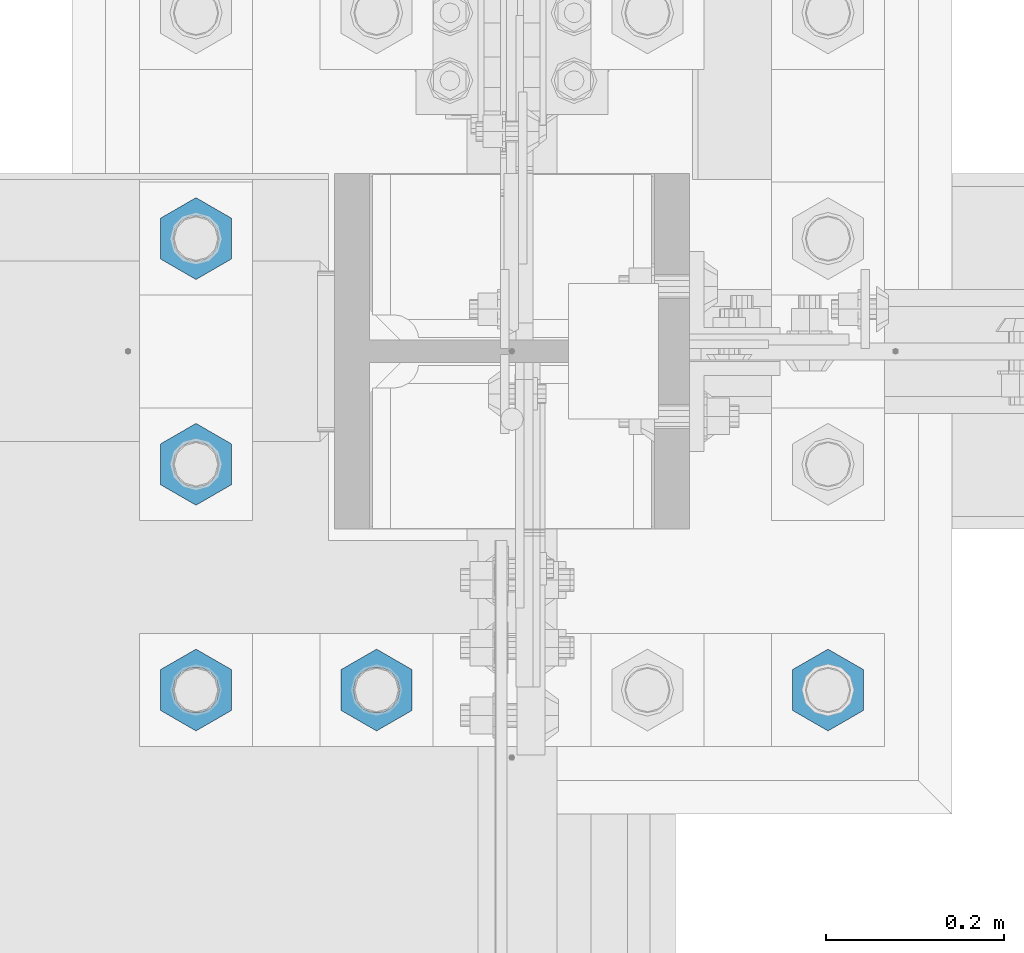
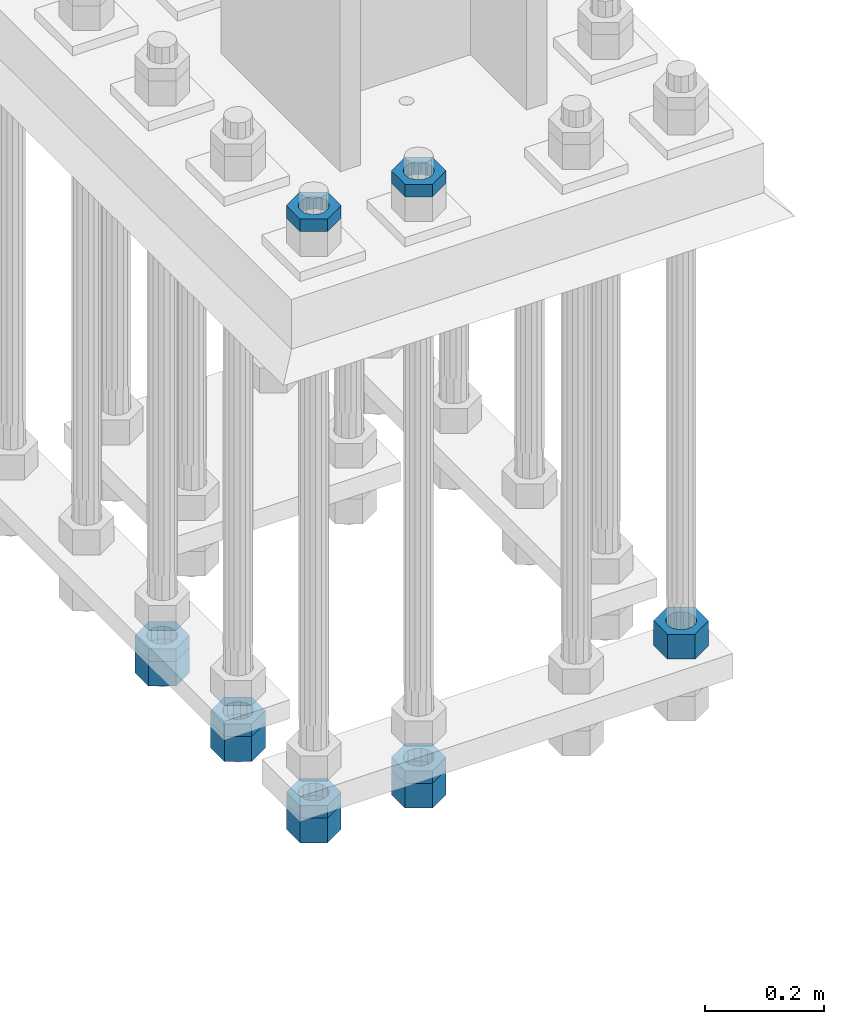
# One storey, part 2194 of 3843: 11 beams, 1 element without a shape of its own.
"""IFC2X3 building model written with IfcOpenShell, lengths in millimetres."""

from ifc_helpers import new_model, si_unit, frame, origin_with_axes, place, context, subcontext, project, spatial, faceted_brep, material, type_object, element, aggregate, save


model = new_model("IFC2X3")

# Units and contexts
model_context = context("Model", 3, precision=1e-05, world=origin_with_axes())
body_context = subcontext(model_context, "Body", "Model", "MODEL_VIEW")
ifc_project = project(units=[si_unit("LENGTHUNIT", "METRE", prefix="MILLI"), si_unit("AREAUNIT", "SQUARE_METRE"), si_unit("VOLUMEUNIT", "CUBIC_METRE"), si_unit("MASSUNIT", "GRAM", prefix="KILO"), si_unit("TIMEUNIT", "SECOND"), si_unit("PLANEANGLEUNIT", "RADIAN"), si_unit("SOLIDANGLEUNIT", "STERADIAN"), si_unit("THERMODYNAMICTEMPERATUREUNIT", "DEGREE_CELSIUS"), si_unit("LUMINOUSINTENSITYUNIT", "LUMEN")], contexts=[model_context])

# Site, building, storey
site_placement = place(None, origin_with_axes())
site = spatial("IfcSite", under=ifc_project, at=site_placement, CompositionType="ELEMENT")
building_placement = place(site_placement, origin_with_axes())
building = spatial("IfcBuilding", under=site, at=building_placement, Name="Undefined", CompositionType="ELEMENT")
storey_placement = place(building_placement, origin_with_axes())
storey = spatial("IfcBuildingStorey", under=building, at=storey_placement, Name="Undefined", CompositionType="ELEMENT", Elevation=0.0)

# Assembly, beams
assembly_placement = place(storey_placement, origin_with_axes())
assembly = element("IfcElementAssembly", 1, at=assembly_placement, inside=storey, Name="TEMPLATE", AssemblyPlace="NOTDEFINED", PredefinedType="RIGID_FRAME")
ifc_material = material(Name="STEEL/A572-50")
beam_type_1 = type_object("IfcBeamType", Name="2_HALF_NUT", PredefinedType="NOTDEFINED")
beam_1_placement = place(assembly_placement, frame((36220.4, 50177.7, 30257.75), z_axis=(1.0, 0.0, 0.0), x_axis=(0.0, 0.0, -1.0)))
beam_1 = element("IfcBeam", 2, at=beam_1_placement, type_object=beam_type_1, material=ifc_material, Name="NUT", ObjectType="2_HALF_NUT", context=body_context, shape_type="Brep", body=[
    faceted_brep([(0.0, -46.0369987487793, 0.0), (0.0, -23.0184993743896, -39.869213104248), (25.4000000000015, -23.0184993743896, -39.869213104248), (25.4000000000015, -46.0369987487793, 0.0), (0.0, 23.0184993743896, -39.869213104248), (25.4000000000015, 23.0184993743896, -39.869213104248), (0.0, 46.0369987487793, 0.0), (25.4000000000015, 46.0369987487793, 0.0), (0.0, 23.0184993743896, 39.869213104248), (25.4000000000015, 23.0184993743896, 39.869213104248), (0.0, -23.0184993743896, 39.869213104248), (25.4000000000015, -23.0184993743896, 39.869213104248), (0.0, 0.0, 26.1940002441406), (0.0, 11.3650617044477, 23.5999013092805), (25.4000000000015, 11.3650617044477, 23.5999013092805), (25.4000000000015, 0.0, 26.1940002441406), (0.0, 20.4791109456419, 16.3316083006721), (25.4000000000015, 20.4791109456419, 16.3316083006721), (0.0, 25.5370200498292, 5.82867859874386), (25.4000000000015, 25.5370200498292, 5.82867859874386), (0.0, 25.5370200498292, -5.82867859874386), (25.4000000000015, 25.5370200498292, -5.82867859874386), (0.0, 20.4791109456419, -16.3316083006721), (25.4000000000015, 20.4791109456419, -16.3316083006721), (0.0, 11.3650617044477, -23.5999013092805), (25.4000000000015, 11.3650617044477, -23.5999013092805), (0.0, 0.0, -26.1940002441406), (25.4000000000015, 0.0, -26.1940002441406), (0.0, -11.3650617044477, -23.5999013092805), (25.4000000000015, -11.3650617044477, -23.5999013092805), (0.0, -20.4791109456419, -16.3316083006721), (25.4000000000015, -20.4791109456419, -16.3316083006721), (0.0, -25.5370200498292, -5.82867859874386), (25.4000000000015, -25.5370200498292, -5.82867859874386), (0.0, -25.5370200498292, 5.82867859874386), (25.4000000000015, -25.5370200498292, 5.82867859874386), (0.0, -20.4791109456419, 16.3316083006721), (25.4000000000015, -20.4791109456419, 16.3316083006721), (0.0, -11.3650617044477, 23.5999013092805), (25.4000000000015, -11.3650617044477, 23.5999013092805)], [[[0, 1, 2, 3]], [[1, 4, 5, 2]], [[4, 6, 7, 5]], [[6, 8, 9, 7]], [[8, 10, 11, 9]], [[10, 0, 3, 11]], [[12, 13, 14, 15]], [[13, 16, 17, 14]], [[16, 18, 19, 17]], [[18, 20, 21, 19]], [[20, 22, 23, 21]], [[22, 24, 25, 23]], [[24, 26, 27, 25]], [[26, 28, 29, 27]], [[28, 30, 31, 29]], [[30, 32, 33, 31]], [[32, 34, 35, 33]], [[34, 36, 37, 35]], [[36, 38, 39, 37]], [[38, 12, 15, 39]], [[5, 7, 9, 11, 3, 2], [17, 19, 21, 23, 25, 27, 29, 31, 33, 35, 37, 39, 15, 14]], [[10, 8, 6, 4, 1, 0], [38, 36, 34, 32, 30, 28, 26, 24, 22, 20, 18, 16, 13, 12]]]),
])
beam_2_placement = place(assembly_placement, frame((36423.6, 50177.7, 30257.75), z_axis=(1.0, 0.0, 0.0), x_axis=(0.0, 0.0, -1.0)))
beam_2 = element("IfcBeam", 3, at=beam_2_placement, type_object=beam_type_1, material=ifc_material, Name="NUT", ObjectType="2_HALF_NUT", context=body_context, shape_type="Brep", body=[
    faceted_brep([(0.0, -46.0369987487793, 0.0), (0.0, -23.0184993743896, -39.869213104248), (25.4000000000015, -23.0184993743896, -39.869213104248), (25.4000000000015, -46.0369987487793, 0.0), (0.0, 23.0184993743896, -39.869213104248), (25.4000000000015, 23.0184993743896, -39.869213104248), (0.0, 46.0369987487793, 0.0), (25.4000000000015, 46.0369987487793, 0.0), (0.0, 23.0184993743896, 39.869213104248), (25.4000000000015, 23.0184993743896, 39.869213104248), (0.0, -23.0184993743896, 39.869213104248), (25.4000000000015, -23.0184993743896, 39.869213104248), (0.0, 0.0, 26.1940002441406), (0.0, 11.3650617044477, 23.5999013092805), (25.4000000000015, 11.3650617044477, 23.5999013092805), (25.4000000000015, 0.0, 26.1940002441406), (0.0, 20.4791109456419, 16.3316083006721), (25.4000000000015, 20.4791109456419, 16.3316083006721), (0.0, 25.5370200498292, 5.82867859874386), (25.4000000000015, 25.5370200498292, 5.82867859874386), (0.0, 25.5370200498292, -5.82867859874386), (25.4000000000015, 25.5370200498292, -5.82867859874386), (0.0, 20.4791109456419, -16.3316083006721), (25.4000000000015, 20.4791109456419, -16.3316083006721), (0.0, 11.3650617044477, -23.5999013092805), (25.4000000000015, 11.3650617044477, -23.5999013092805), (0.0, 0.0, -26.1940002441406), (25.4000000000015, 0.0, -26.1940002441406), (0.0, -11.3650617044477, -23.5999013092805), (25.4000000000015, -11.3650617044477, -23.5999013092805), (0.0, -20.4791109456419, -16.3316083006721), (25.4000000000015, -20.4791109456419, -16.3316083006721), (0.0, -25.5370200498292, -5.82867859874386), (25.4000000000015, -25.5370200498292, -5.82867859874386), (0.0, -25.5370200498292, 5.82867859874386), (25.4000000000015, -25.5370200498292, 5.82867859874386), (0.0, -20.4791109456419, 16.3316083006721), (25.4000000000015, -20.4791109456419, 16.3316083006721), (0.0, -11.3650617044477, 23.5999013092805), (25.4000000000015, -11.3650617044477, 23.5999013092805)], [[[0, 1, 2, 3]], [[1, 4, 5, 2]], [[4, 6, 7, 5]], [[6, 8, 9, 7]], [[8, 10, 11, 9]], [[10, 0, 3, 11]], [[12, 13, 14, 15]], [[13, 16, 17, 14]], [[16, 18, 19, 17]], [[18, 20, 21, 19]], [[20, 22, 23, 21]], [[22, 24, 25, 23]], [[24, 26, 27, 25]], [[26, 28, 29, 27]], [[28, 30, 31, 29]], [[30, 32, 33, 31]], [[32, 34, 35, 33]], [[34, 36, 37, 35]], [[36, 38, 39, 37]], [[38, 12, 15, 39]], [[5, 7, 9, 11, 3, 2], [17, 19, 21, 23, 25, 27, 29, 31, 33, 35, 37, 39, 15, 14]], [[10, 8, 6, 4, 1, 0], [38, 36, 34, 32, 30, 28, 26, 24, 22, 20, 18, 16, 13, 12]]]),
])
beam_3_placement = place(assembly_placement, frame((36423.6, 50177.7, 29057.6), z_axis=(1.0, 0.0, 0.0), x_axis=(0.0, 0.0, -1.0)))
beam_3 = element("IfcBeam", 4, at=beam_3_placement, type_object=beam_type_1, material=ifc_material, Name="NUT", ObjectType="2_HALF_NUT", context=body_context, shape_type="Brep", body=[
    faceted_brep([(0.0, -46.0369987487793, 0.0), (0.0, -23.0184993743896, -39.869213104248), (25.4000000000015, -23.0184993743896, -39.869213104248), (25.4000000000015, -46.0369987487793, 0.0), (0.0, 23.0184993743896, -39.869213104248), (25.4000000000015, 23.0184993743896, -39.869213104248), (0.0, 46.0369987487793, 0.0), (25.4000000000015, 46.0369987487793, 0.0), (0.0, 23.0184993743896, 39.869213104248), (25.4000000000015, 23.0184993743896, 39.869213104248), (0.0, -23.0184993743896, 39.869213104248), (25.4000000000015, -23.0184993743896, 39.869213104248), (0.0, 0.0, 26.1940002441406), (0.0, 11.3650617044477, 23.5999013092805), (25.4000000000015, 11.3650617044477, 23.5999013092805), (25.4000000000015, 0.0, 26.1940002441406), (0.0, 20.4791109456419, 16.3316083006721), (25.4000000000015, 20.4791109456419, 16.3316083006721), (0.0, 25.5370200498292, 5.82867859874386), (25.4000000000015, 25.5370200498292, 5.82867859874386), (0.0, 25.5370200498292, -5.82867859874386), (25.4000000000015, 25.5370200498292, -5.82867859874386), (0.0, 20.4791109456419, -16.3316083006721), (25.4000000000015, 20.4791109456419, -16.3316083006721), (0.0, 11.3650617044477, -23.5999013092805), (25.4000000000015, 11.3650617044477, -23.5999013092805), (0.0, 0.0, -26.1940002441406), (25.4000000000015, 0.0, -26.1940002441406), (0.0, -11.3650617044477, -23.5999013092805), (25.4000000000015, -11.3650617044477, -23.5999013092805), (0.0, -20.4791109456419, -16.3316083006721), (25.4000000000015, -20.4791109456419, -16.3316083006721), (0.0, -25.5370200498292, -5.82867859874386), (25.4000000000015, -25.5370200498292, -5.82867859874386), (0.0, -25.5370200498292, 5.82867859874386), (25.4000000000015, -25.5370200498292, 5.82867859874386), (0.0, -20.4791109456419, 16.3316083006721), (25.4000000000015, -20.4791109456419, 16.3316083006721), (0.0, -11.3650617044477, 23.5999013092805), (25.4000000000015, -11.3650617044477, 23.5999013092805)], [[[0, 1, 2, 3]], [[1, 4, 5, 2]], [[4, 6, 7, 5]], [[6, 8, 9, 7]], [[8, 10, 11, 9]], [[10, 0, 3, 11]], [[12, 13, 14, 15]], [[13, 16, 17, 14]], [[16, 18, 19, 17]], [[18, 20, 21, 19]], [[20, 22, 23, 21]], [[22, 24, 25, 23]], [[24, 26, 27, 25]], [[26, 28, 29, 27]], [[28, 30, 31, 29]], [[30, 32, 33, 31]], [[32, 34, 35, 33]], [[34, 36, 37, 35]], [[36, 38, 39, 37]], [[38, 12, 15, 39]], [[5, 7, 9, 11, 3, 2], [17, 19, 21, 23, 25, 27, 29, 31, 33, 35, 37, 39, 15, 14]], [[10, 8, 6, 4, 1, 0], [38, 36, 34, 32, 30, 28, 26, 24, 22, 20, 18, 16, 13, 12]]]),
])
beam_4_placement = place(assembly_placement, frame((36220.4, 50177.7, 29057.6), z_axis=(1.0, 0.0, 0.0), x_axis=(0.0, 0.0, -1.0)))
beam_4 = element("IfcBeam", 5, at=beam_4_placement, type_object=beam_type_1, material=ifc_material, Name="NUT", ObjectType="2_HALF_NUT", context=body_context, shape_type="Brep", body=[
    faceted_brep([(0.0, -46.0369987487793, 0.0), (0.0, -23.0184993743896, -39.869213104248), (25.4000000000015, -23.0184993743896, -39.869213104248), (25.4000000000015, -46.0369987487793, 0.0), (0.0, 23.0184993743896, -39.869213104248), (25.4000000000015, 23.0184993743896, -39.869213104248), (0.0, 46.0369987487793, 0.0), (25.4000000000015, 46.0369987487793, 0.0), (0.0, 23.0184993743896, 39.869213104248), (25.4000000000015, 23.0184993743896, 39.869213104248), (0.0, -23.0184993743896, 39.869213104248), (25.4000000000015, -23.0184993743896, 39.869213104248), (0.0, 0.0, 26.1940002441406), (0.0, 11.3650617044477, 23.5999013092805), (25.4000000000015, 11.3650617044477, 23.5999013092805), (25.4000000000015, 0.0, 26.1940002441406), (0.0, 20.4791109456419, 16.3316083006721), (25.4000000000015, 20.4791109456419, 16.3316083006721), (0.0, 25.5370200498292, 5.82867859874386), (25.4000000000015, 25.5370200498292, 5.82867859874386), (0.0, 25.5370200498292, -5.82867859874386), (25.4000000000015, 25.5370200498292, -5.82867859874386), (0.0, 20.4791109456419, -16.3316083006721), (25.4000000000015, 20.4791109456419, -16.3316083006721), (0.0, 11.3650617044477, -23.5999013092805), (25.4000000000015, 11.3650617044477, -23.5999013092805), (0.0, 0.0, -26.1940002441406), (25.4000000000015, 0.0, -26.1940002441406), (0.0, -11.3650617044477, -23.5999013092805), (25.4000000000015, -11.3650617044477, -23.5999013092805), (0.0, -20.4791109456419, -16.3316083006721), (25.4000000000015, -20.4791109456419, -16.3316083006721), (0.0, -25.5370200498292, -5.82867859874386), (25.4000000000015, -25.5370200498292, -5.82867859874386), (0.0, -25.5370200498292, 5.82867859874386), (25.4000000000015, -25.5370200498292, 5.82867859874386), (0.0, -20.4791109456419, 16.3316083006721), (25.4000000000015, -20.4791109456419, 16.3316083006721), (0.0, -11.3650617044477, 23.5999013092805), (25.4000000000015, -11.3650617044477, 23.5999013092805)], [[[0, 1, 2, 3]], [[1, 4, 5, 2]], [[4, 6, 7, 5]], [[6, 8, 9, 7]], [[8, 10, 11, 9]], [[10, 0, 3, 11]], [[12, 13, 14, 15]], [[13, 16, 17, 14]], [[16, 18, 19, 17]], [[18, 20, 21, 19]], [[20, 22, 23, 21]], [[22, 24, 25, 23]], [[24, 26, 27, 25]], [[26, 28, 29, 27]], [[28, 30, 31, 29]], [[30, 32, 33, 31]], [[32, 34, 35, 33]], [[34, 36, 37, 35]], [[36, 38, 39, 37]], [[38, 12, 15, 39]], [[5, 7, 9, 11, 3, 2], [17, 19, 21, 23, 25, 27, 29, 31, 33, 35, 37, 39, 15, 14]], [[10, 8, 6, 4, 1, 0], [38, 36, 34, 32, 30, 28, 26, 24, 22, 20, 18, 16, 13, 12]]]),
])
beam_5_placement = place(assembly_placement, frame((36220.4, 50431.7, 29070.3), z_axis=(1.0, 0.0, 0.0), x_axis=(0.0, 0.0, -1.0)))
beam_5 = element("IfcBeam", 6, at=beam_5_placement, type_object=beam_type_1, material=ifc_material, Name="NUT", ObjectType="2_HALF_NUT", context=body_context, shape_type="Brep", body=[
    faceted_brep([(0.0, -46.0369987487793, 0.0), (0.0, -23.0184993743896, -39.869213104248), (25.4000000000015, -23.0184993743896, -39.869213104248), (25.4000000000015, -46.0369987487793, 0.0), (0.0, 23.0184993743896, -39.869213104248), (25.4000000000015, 23.0184993743896, -39.869213104248), (0.0, 46.0369987487793, 0.0), (25.4000000000015, 46.0369987487793, 0.0), (0.0, 23.0184993743896, 39.869213104248), (25.4000000000015, 23.0184993743896, 39.869213104248), (0.0, -23.0184993743896, 39.869213104248), (25.4000000000015, -23.0184993743896, 39.869213104248), (0.0, 0.0, 26.1940002441406), (0.0, 11.3650617044477, 23.5999013092805), (25.4000000000015, 11.3650617044477, 23.5999013092805), (25.4000000000015, 0.0, 26.1940002441406), (0.0, 20.4791109456419, 16.3316083006721), (25.4000000000015, 20.4791109456419, 16.3316083006721), (0.0, 25.5370200498292, 5.82867859874386), (25.4000000000015, 25.5370200498292, 5.82867859874386), (0.0, 25.5370200498292, -5.82867859874386), (25.4000000000015, 25.5370200498292, -5.82867859874386), (0.0, 20.4791109456419, -16.3316083006721), (25.4000000000015, 20.4791109456419, -16.3316083006721), (0.0, 11.3650617044477, -23.5999013092805), (25.4000000000015, 11.3650617044477, -23.5999013092805), (0.0, 0.0, -26.1940002441406), (25.4000000000015, 0.0, -26.1940002441406), (0.0, -11.3650617044477, -23.5999013092805), (25.4000000000015, -11.3650617044477, -23.5999013092805), (0.0, -20.4791109456419, -16.3316083006721), (25.4000000000015, -20.4791109456419, -16.3316083006721), (0.0, -25.5370200498292, -5.82867859874386), (25.4000000000015, -25.5370200498292, -5.82867859874386), (0.0, -25.5370200498292, 5.82867859874386), (25.4000000000015, -25.5370200498292, 5.82867859874386), (0.0, -20.4791109456419, 16.3316083006721), (25.4000000000015, -20.4791109456419, 16.3316083006721), (0.0, -11.3650617044477, 23.5999013092805), (25.4000000000015, -11.3650617044477, 23.5999013092805)], [[[0, 1, 2, 3]], [[1, 4, 5, 2]], [[4, 6, 7, 5]], [[6, 8, 9, 7]], [[8, 10, 11, 9]], [[10, 0, 3, 11]], [[12, 13, 14, 15]], [[13, 16, 17, 14]], [[16, 18, 19, 17]], [[18, 20, 21, 19]], [[20, 22, 23, 21]], [[22, 24, 25, 23]], [[24, 26, 27, 25]], [[26, 28, 29, 27]], [[28, 30, 31, 29]], [[30, 32, 33, 31]], [[32, 34, 35, 33]], [[34, 36, 37, 35]], [[36, 38, 39, 37]], [[38, 12, 15, 39]], [[5, 7, 9, 11, 3, 2], [17, 19, 21, 23, 25, 27, 29, 31, 33, 35, 37, 39, 15, 14]], [[10, 8, 6, 4, 1, 0], [38, 36, 34, 32, 30, 28, 26, 24, 22, 20, 18, 16, 13, 12]]]),
])
beam_6_placement = place(assembly_placement, frame((36220.4, 50685.7, 29070.3), z_axis=(1.0, 0.0, 0.0), x_axis=(0.0, 0.0, -1.0)))
beam_6 = element("IfcBeam", 7, at=beam_6_placement, type_object=beam_type_1, material=ifc_material, Name="NUT", ObjectType="2_HALF_NUT", context=body_context, shape_type="Brep", body=[
    faceted_brep([(0.0, -46.0369987487793, 0.0), (0.0, -23.0184993743896, -39.869213104248), (25.4000000000015, -23.0184993743896, -39.869213104248), (25.4000000000015, -46.0369987487793, 0.0), (0.0, 23.0184993743896, -39.869213104248), (25.4000000000015, 23.0184993743896, -39.869213104248), (0.0, 46.0369987487793, 0.0), (25.4000000000015, 46.0369987487793, 0.0), (0.0, 23.0184993743896, 39.869213104248), (25.4000000000015, 23.0184993743896, 39.869213104248), (0.0, -23.0184993743896, 39.869213104248), (25.4000000000015, -23.0184993743896, 39.869213104248), (0.0, 0.0, 26.1940002441406), (0.0, 11.3650617044477, 23.5999013092805), (25.4000000000015, 11.3650617044477, 23.5999013092805), (25.4000000000015, 0.0, 26.1940002441406), (0.0, 20.4791109456419, 16.3316083006721), (25.4000000000015, 20.4791109456419, 16.3316083006721), (0.0, 25.5370200498292, 5.82867859874386), (25.4000000000015, 25.5370200498292, 5.82867859874386), (0.0, 25.5370200498292, -5.82867859874386), (25.4000000000015, 25.5370200498292, -5.82867859874386), (0.0, 20.4791109456419, -16.3316083006721), (25.4000000000015, 20.4791109456419, -16.3316083006721), (0.0, 11.3650617044477, -23.5999013092805), (25.4000000000015, 11.3650617044477, -23.5999013092805), (0.0, 0.0, -26.1940002441406), (25.4000000000015, 0.0, -26.1940002441406), (0.0, -11.3650617044477, -23.5999013092805), (25.4000000000015, -11.3650617044477, -23.5999013092805), (0.0, -20.4791109456419, -16.3316083006721), (25.4000000000015, -20.4791109456419, -16.3316083006721), (0.0, -25.5370200498292, -5.82867859874386), (25.4000000000015, -25.5370200498292, -5.82867859874386), (0.0, -25.5370200498292, 5.82867859874386), (25.4000000000015, -25.5370200498292, 5.82867859874386), (0.0, -20.4791109456419, 16.3316083006721), (25.4000000000015, -20.4791109456419, 16.3316083006721), (0.0, -11.3650617044477, 23.5999013092805), (25.4000000000015, -11.3650617044477, 23.5999013092805)], [[[0, 1, 2, 3]], [[1, 4, 5, 2]], [[4, 6, 7, 5]], [[6, 8, 9, 7]], [[8, 10, 11, 9]], [[10, 0, 3, 11]], [[12, 13, 14, 15]], [[13, 16, 17, 14]], [[16, 18, 19, 17]], [[18, 20, 21, 19]], [[20, 22, 23, 21]], [[22, 24, 25, 23]], [[24, 26, 27, 25]], [[26, 28, 29, 27]], [[28, 30, 31, 29]], [[30, 32, 33, 31]], [[32, 34, 35, 33]], [[34, 36, 37, 35]], [[36, 38, 39, 37]], [[38, 12, 15, 39]], [[5, 7, 9, 11, 3, 2], [17, 19, 21, 23, 25, 27, 29, 31, 33, 35, 37, 39, 15, 14]], [[10, 8, 6, 4, 1, 0], [38, 36, 34, 32, 30, 28, 26, 24, 22, 20, 18, 16, 13, 12]]]),
])
beam_type_2 = type_object("IfcBeamType", Name="2_HEAVY_HEX_NUT", PredefinedType="NOTDEFINED")
beam_7_placement = place(assembly_placement, frame((36931.6, 50177.7, 29159.2), z_axis=(1.0, 0.0, 0.0), x_axis=(0.0, 0.0, -1.0)))
beam_7 = element("IfcBeam", 8, at=beam_7_placement, type_object=beam_type_2, material=ifc_material, Name="NUT", ObjectType="2_HEAVY_HEX_NUT", context=body_context, shape_type="Brep", body=[
    faceted_brep([(0.0, -46.0369987487793, 0.0), (0.0, -23.0184993743896, -39.869213104248), (50.7999999999993, -23.0184993743896, -39.869213104248), (50.7999999999993, -46.0369987487793, 0.0), (0.0, 23.0184993743896, -39.869213104248), (50.7999999999993, 23.0184993743896, -39.869213104248), (0.0, 46.0369987487793, 0.0), (50.7999999999993, 46.0369987487793, 0.0), (0.0, 23.0184993743896, 39.869213104248), (50.7999999999993, 23.0184993743896, 39.869213104248), (0.0, -23.0184993743896, 39.869213104248), (50.7999999999993, -23.0184993743896, 39.869213104248), (0.0, 0.0, 26.1940002441406), (0.0, 11.3650617044477, 23.5999013092805), (50.7999999999993, 11.3650617044477, 23.5999013092805), (50.7999999999993, 0.0, 26.1940002441406), (0.0, 20.4791109456419, 16.3316083006721), (50.7999999999993, 20.4791109456419, 16.3316083006721), (0.0, 25.5370200498292, 5.82867859874386), (50.7999999999993, 25.5370200498292, 5.82867859874386), (0.0, 25.5370200498292, -5.82867859874386), (50.7999999999993, 25.5370200498292, -5.82867859874386), (0.0, 20.4791109456419, -16.3316083006721), (50.7999999999993, 20.4791109456419, -16.3316083006721), (0.0, 11.3650617044477, -23.5999013092805), (50.7999999999993, 11.3650617044477, -23.5999013092805), (0.0, 0.0, -26.1940002441406), (50.7999999999993, 0.0, -26.1940002441406), (0.0, -11.3650617044477, -23.5999013092805), (50.7999999999993, -11.3650617044477, -23.5999013092805), (0.0, -20.4791109456419, -16.3316083006721), (50.7999999999993, -20.4791109456419, -16.3316083006721), (0.0, -25.5370200498292, -5.82867859874386), (50.7999999999993, -25.5370200498292, -5.82867859874386), (0.0, -25.5370200498292, 5.82867859874386), (50.7999999999993, -25.5370200498292, 5.82867859874386), (0.0, -20.4791109456419, 16.3316083006721), (50.7999999999993, -20.4791109456419, 16.3316083006721), (0.0, -11.3650617044477, 23.5999013092805), (50.7999999999993, -11.3650617044477, 23.5999013092805)], [[[0, 1, 2, 3]], [[1, 4, 5, 2]], [[4, 6, 7, 5]], [[6, 8, 9, 7]], [[8, 10, 11, 9]], [[10, 0, 3, 11]], [[12, 13, 14, 15]], [[13, 16, 17, 14]], [[16, 18, 19, 17]], [[18, 20, 21, 19]], [[20, 22, 23, 21]], [[22, 24, 25, 23]], [[24, 26, 27, 25]], [[26, 28, 29, 27]], [[28, 30, 31, 29]], [[30, 32, 33, 31]], [[32, 34, 35, 33]], [[34, 36, 37, 35]], [[36, 38, 39, 37]], [[38, 12, 15, 39]], [[5, 7, 9, 11, 3, 2], [17, 19, 21, 23, 25, 27, 29, 31, 33, 35, 37, 39, 15, 14]], [[10, 8, 6, 4, 1, 0], [38, 36, 34, 32, 30, 28, 26, 24, 22, 20, 18, 16, 13, 12]]]),
])
beam_8_placement = place(assembly_placement, frame((36423.6, 50177.7, 29032.2), z_axis=(1.0, 0.0, 0.0), x_axis=(0.0, 0.0, -1.0)))
beam_8 = element("IfcBeam", 9, at=beam_8_placement, type_object=beam_type_2, material=ifc_material, Name="NUT", ObjectType="2_HEAVY_HEX_NUT", context=body_context, shape_type="Brep", body=[
    faceted_brep([(0.0, -46.0369987487793, 0.0), (0.0, -23.0184993743896, -39.869213104248), (50.7999999999993, -23.0184993743896, -39.869213104248), (50.7999999999993, -46.0369987487793, 0.0), (0.0, 23.0184993743896, -39.869213104248), (50.7999999999993, 23.0184993743896, -39.869213104248), (0.0, 46.0369987487793, 0.0), (50.7999999999993, 46.0369987487793, 0.0), (0.0, 23.0184993743896, 39.869213104248), (50.7999999999993, 23.0184993743896, 39.869213104248), (0.0, -23.0184993743896, 39.869213104248), (50.7999999999993, -23.0184993743896, 39.869213104248), (0.0, 0.0, 26.1940002441406), (0.0, 11.3650617044477, 23.5999013092805), (50.7999999999993, 11.3650617044477, 23.5999013092805), (50.7999999999993, 0.0, 26.1940002441406), (0.0, 20.4791109456419, 16.3316083006721), (50.7999999999993, 20.4791109456419, 16.3316083006721), (0.0, 25.5370200498292, 5.82867859874386), (50.7999999999993, 25.5370200498292, 5.82867859874386), (0.0, 25.5370200498292, -5.82867859874386), (50.7999999999993, 25.5370200498292, -5.82867859874386), (0.0, 20.4791109456419, -16.3316083006721), (50.7999999999993, 20.4791109456419, -16.3316083006721), (0.0, 11.3650617044477, -23.5999013092805), (50.7999999999993, 11.3650617044477, -23.5999013092805), (0.0, 0.0, -26.1940002441406), (50.7999999999993, 0.0, -26.1940002441406), (0.0, -11.3650617044477, -23.5999013092805), (50.7999999999993, -11.3650617044477, -23.5999013092805), (0.0, -20.4791109456419, -16.3316083006721), (50.7999999999993, -20.4791109456419, -16.3316083006721), (0.0, -25.5370200498292, -5.82867859874386), (50.7999999999993, -25.5370200498292, -5.82867859874386), (0.0, -25.5370200498292, 5.82867859874386), (50.7999999999993, -25.5370200498292, 5.82867859874386), (0.0, -20.4791109456419, 16.3316083006721), (50.7999999999993, -20.4791109456419, 16.3316083006721), (0.0, -11.3650617044477, 23.5999013092805), (50.7999999999993, -11.3650617044477, 23.5999013092805)], [[[0, 1, 2, 3]], [[1, 4, 5, 2]], [[4, 6, 7, 5]], [[6, 8, 9, 7]], [[8, 10, 11, 9]], [[10, 0, 3, 11]], [[12, 13, 14, 15]], [[13, 16, 17, 14]], [[16, 18, 19, 17]], [[18, 20, 21, 19]], [[20, 22, 23, 21]], [[22, 24, 25, 23]], [[24, 26, 27, 25]], [[26, 28, 29, 27]], [[28, 30, 31, 29]], [[30, 32, 33, 31]], [[32, 34, 35, 33]], [[34, 36, 37, 35]], [[36, 38, 39, 37]], [[38, 12, 15, 39]], [[5, 7, 9, 11, 3, 2], [17, 19, 21, 23, 25, 27, 29, 31, 33, 35, 37, 39, 15, 14]], [[10, 8, 6, 4, 1, 0], [38, 36, 34, 32, 30, 28, 26, 24, 22, 20, 18, 16, 13, 12]]]),
])
beam_9_placement = place(assembly_placement, frame((36220.4, 50177.7, 29032.2), z_axis=(1.0, 0.0, 0.0), x_axis=(0.0, 0.0, -1.0)))
beam_9 = element("IfcBeam", 10, at=beam_9_placement, type_object=beam_type_2, material=ifc_material, Name="NUT", ObjectType="2_HEAVY_HEX_NUT", context=body_context, shape_type="Brep", body=[
    faceted_brep([(0.0, -46.0369987487793, 0.0), (0.0, -23.0184993743896, -39.869213104248), (50.7999999999993, -23.0184993743896, -39.869213104248), (50.7999999999993, -46.0369987487793, 0.0), (0.0, 23.0184993743896, -39.869213104248), (50.7999999999993, 23.0184993743896, -39.869213104248), (0.0, 46.0369987487793, 0.0), (50.7999999999993, 46.0369987487793, 0.0), (0.0, 23.0184993743896, 39.869213104248), (50.7999999999993, 23.0184993743896, 39.869213104248), (0.0, -23.0184993743896, 39.869213104248), (50.7999999999993, -23.0184993743896, 39.869213104248), (0.0, 0.0, 26.1940002441406), (0.0, 11.3650617044477, 23.5999013092805), (50.7999999999993, 11.3650617044477, 23.5999013092805), (50.7999999999993, 0.0, 26.1940002441406), (0.0, 20.4791109456419, 16.3316083006721), (50.7999999999993, 20.4791109456419, 16.3316083006721), (0.0, 25.5370200498292, 5.82867859874386), (50.7999999999993, 25.5370200498292, 5.82867859874386), (0.0, 25.5370200498292, -5.82867859874386), (50.7999999999993, 25.5370200498292, -5.82867859874386), (0.0, 20.4791109456419, -16.3316083006721), (50.7999999999993, 20.4791109456419, -16.3316083006721), (0.0, 11.3650617044477, -23.5999013092805), (50.7999999999993, 11.3650617044477, -23.5999013092805), (0.0, 0.0, -26.1940002441406), (50.7999999999993, 0.0, -26.1940002441406), (0.0, -11.3650617044477, -23.5999013092805), (50.7999999999993, -11.3650617044477, -23.5999013092805), (0.0, -20.4791109456419, -16.3316083006721), (50.7999999999993, -20.4791109456419, -16.3316083006721), (0.0, -25.5370200498292, -5.82867859874386), (50.7999999999993, -25.5370200498292, -5.82867859874386), (0.0, -25.5370200498292, 5.82867859874386), (50.7999999999993, -25.5370200498292, 5.82867859874386), (0.0, -20.4791109456419, 16.3316083006721), (50.7999999999993, -20.4791109456419, 16.3316083006721), (0.0, -11.3650617044477, 23.5999013092805), (50.7999999999993, -11.3650617044477, 23.5999013092805)], [[[0, 1, 2, 3]], [[1, 4, 5, 2]], [[4, 6, 7, 5]], [[6, 8, 9, 7]], [[8, 10, 11, 9]], [[10, 0, 3, 11]], [[12, 13, 14, 15]], [[13, 16, 17, 14]], [[16, 18, 19, 17]], [[18, 20, 21, 19]], [[20, 22, 23, 21]], [[22, 24, 25, 23]], [[24, 26, 27, 25]], [[26, 28, 29, 27]], [[28, 30, 31, 29]], [[30, 32, 33, 31]], [[32, 34, 35, 33]], [[34, 36, 37, 35]], [[36, 38, 39, 37]], [[38, 12, 15, 39]], [[5, 7, 9, 11, 3, 2], [17, 19, 21, 23, 25, 27, 29, 31, 33, 35, 37, 39, 15, 14]], [[10, 8, 6, 4, 1, 0], [38, 36, 34, 32, 30, 28, 26, 24, 22, 20, 18, 16, 13, 12]]]),
])
beam_10_placement = place(assembly_placement, frame((36220.4, 50431.7, 29044.9), z_axis=(1.0, 0.0, 0.0), x_axis=(0.0, 0.0, -1.0)))
beam_10 = element("IfcBeam", 11, at=beam_10_placement, type_object=beam_type_2, material=ifc_material, Name="NUT", ObjectType="2_HEAVY_HEX_NUT", context=body_context, shape_type="Brep", body=[
    faceted_brep([(0.0, -46.0369987487793, 0.0), (0.0, -23.0184993743896, -39.869213104248), (50.7999999999993, -23.0184993743896, -39.869213104248), (50.7999999999993, -46.0369987487793, 0.0), (0.0, 23.0184993743896, -39.869213104248), (50.7999999999993, 23.0184993743896, -39.869213104248), (0.0, 46.0369987487793, 0.0), (50.7999999999993, 46.0369987487793, 0.0), (0.0, 23.0184993743896, 39.869213104248), (50.7999999999993, 23.0184993743896, 39.869213104248), (0.0, -23.0184993743896, 39.869213104248), (50.7999999999993, -23.0184993743896, 39.869213104248), (0.0, 0.0, 26.1940002441406), (0.0, 11.3650617044477, 23.5999013092805), (50.7999999999993, 11.3650617044477, 23.5999013092805), (50.7999999999993, 0.0, 26.1940002441406), (0.0, 20.4791109456419, 16.3316083006721), (50.7999999999993, 20.4791109456419, 16.3316083006721), (0.0, 25.5370200498292, 5.82867859874386), (50.7999999999993, 25.5370200498292, 5.82867859874386), (0.0, 25.5370200498292, -5.82867859874386), (50.7999999999993, 25.5370200498292, -5.82867859874386), (0.0, 20.4791109456419, -16.3316083006721), (50.7999999999993, 20.4791109456419, -16.3316083006721), (0.0, 11.3650617044477, -23.5999013092805), (50.7999999999993, 11.3650617044477, -23.5999013092805), (0.0, 0.0, -26.1940002441406), (50.7999999999993, 0.0, -26.1940002441406), (0.0, -11.3650617044477, -23.5999013092805), (50.7999999999993, -11.3650617044477, -23.5999013092805), (0.0, -20.4791109456419, -16.3316083006721), (50.7999999999993, -20.4791109456419, -16.3316083006721), (0.0, -25.5370200498292, -5.82867859874386), (50.7999999999993, -25.5370200498292, -5.82867859874386), (0.0, -25.5370200498292, 5.82867859874386), (50.7999999999993, -25.5370200498292, 5.82867859874386), (0.0, -20.4791109456419, 16.3316083006721), (50.7999999999993, -20.4791109456419, 16.3316083006721), (0.0, -11.3650617044477, 23.5999013092805), (50.7999999999993, -11.3650617044477, 23.5999013092805)], [[[0, 1, 2, 3]], [[1, 4, 5, 2]], [[4, 6, 7, 5]], [[6, 8, 9, 7]], [[8, 10, 11, 9]], [[10, 0, 3, 11]], [[12, 13, 14, 15]], [[13, 16, 17, 14]], [[16, 18, 19, 17]], [[18, 20, 21, 19]], [[20, 22, 23, 21]], [[22, 24, 25, 23]], [[24, 26, 27, 25]], [[26, 28, 29, 27]], [[28, 30, 31, 29]], [[30, 32, 33, 31]], [[32, 34, 35, 33]], [[34, 36, 37, 35]], [[36, 38, 39, 37]], [[38, 12, 15, 39]], [[5, 7, 9, 11, 3, 2], [17, 19, 21, 23, 25, 27, 29, 31, 33, 35, 37, 39, 15, 14]], [[10, 8, 6, 4, 1, 0], [38, 36, 34, 32, 30, 28, 26, 24, 22, 20, 18, 16, 13, 12]]]),
])
beam_11_placement = place(assembly_placement, frame((36220.4, 50685.7, 29044.9), z_axis=(1.0, 0.0, 0.0), x_axis=(0.0, 0.0, -1.0)))
beam_11 = element("IfcBeam", 12, at=beam_11_placement, type_object=beam_type_2, material=ifc_material, Name="NUT", ObjectType="2_HEAVY_HEX_NUT", context=body_context, shape_type="Brep", body=[
    faceted_brep([(0.0, -46.0369987487793, 0.0), (0.0, -23.0184993743896, -39.869213104248), (50.7999999999993, -23.0184993743896, -39.869213104248), (50.7999999999993, -46.0369987487793, 0.0), (0.0, 23.0184993743896, -39.869213104248), (50.7999999999993, 23.0184993743896, -39.869213104248), (0.0, 46.0369987487793, 0.0), (50.7999999999993, 46.0369987487793, 0.0), (0.0, 23.0184993743896, 39.869213104248), (50.7999999999993, 23.0184993743896, 39.869213104248), (0.0, -23.0184993743896, 39.869213104248), (50.7999999999993, -23.0184993743896, 39.869213104248), (0.0, 0.0, 26.1940002441406), (0.0, 11.3650617044477, 23.5999013092805), (50.7999999999993, 11.3650617044477, 23.5999013092805), (50.7999999999993, 0.0, 26.1940002441406), (0.0, 20.4791109456419, 16.3316083006721), (50.7999999999993, 20.4791109456419, 16.3316083006721), (0.0, 25.5370200498292, 5.82867859874386), (50.7999999999993, 25.5370200498292, 5.82867859874386), (0.0, 25.5370200498292, -5.82867859874386), (50.7999999999993, 25.5370200498292, -5.82867859874386), (0.0, 20.4791109456419, -16.3316083006721), (50.7999999999993, 20.4791109456419, -16.3316083006721), (0.0, 11.3650617044477, -23.5999013092805), (50.7999999999993, 11.3650617044477, -23.5999013092805), (0.0, 0.0, -26.1940002441406), (50.7999999999993, 0.0, -26.1940002441406), (0.0, -11.3650617044477, -23.5999013092805), (50.7999999999993, -11.3650617044477, -23.5999013092805), (0.0, -20.4791109456419, -16.3316083006721), (50.7999999999993, -20.4791109456419, -16.3316083006721), (0.0, -25.5370200498292, -5.82867859874386), (50.7999999999993, -25.5370200498292, -5.82867859874386), (0.0, -25.5370200498292, 5.82867859874386), (50.7999999999993, -25.5370200498292, 5.82867859874386), (0.0, -20.4791109456419, 16.3316083006721), (50.7999999999993, -20.4791109456419, 16.3316083006721), (0.0, -11.3650617044477, 23.5999013092805), (50.7999999999993, -11.3650617044477, 23.5999013092805)], [[[0, 1, 2, 3]], [[1, 4, 5, 2]], [[4, 6, 7, 5]], [[6, 8, 9, 7]], [[8, 10, 11, 9]], [[10, 0, 3, 11]], [[12, 13, 14, 15]], [[13, 16, 17, 14]], [[16, 18, 19, 17]], [[18, 20, 21, 19]], [[20, 22, 23, 21]], [[22, 24, 25, 23]], [[24, 26, 27, 25]], [[26, 28, 29, 27]], [[28, 30, 31, 29]], [[30, 32, 33, 31]], [[32, 34, 35, 33]], [[34, 36, 37, 35]], [[36, 38, 39, 37]], [[38, 12, 15, 39]], [[5, 7, 9, 11, 3, 2], [17, 19, 21, 23, 25, 27, 29, 31, 33, 35, 37, 39, 15, 14]], [[10, 8, 6, 4, 1, 0], [38, 36, 34, 32, 30, 28, 26, 24, 22, 20, 18, 16, 13, 12]]]),
])
aggregate(assembly, [beam_7, beam_1, beam_2, beam_8, beam_3, beam_9, beam_4, beam_10, beam_11, beam_5, beam_6])

save(model, "model.ifc")
